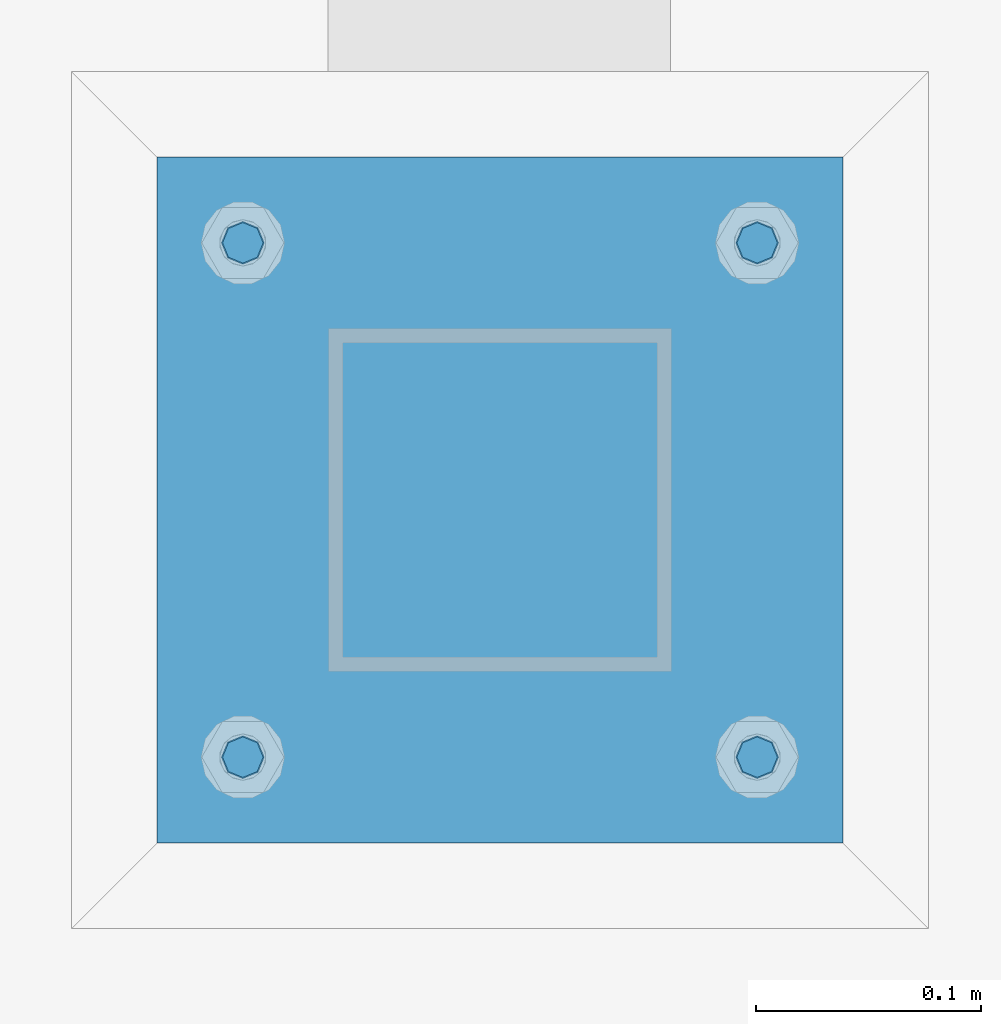
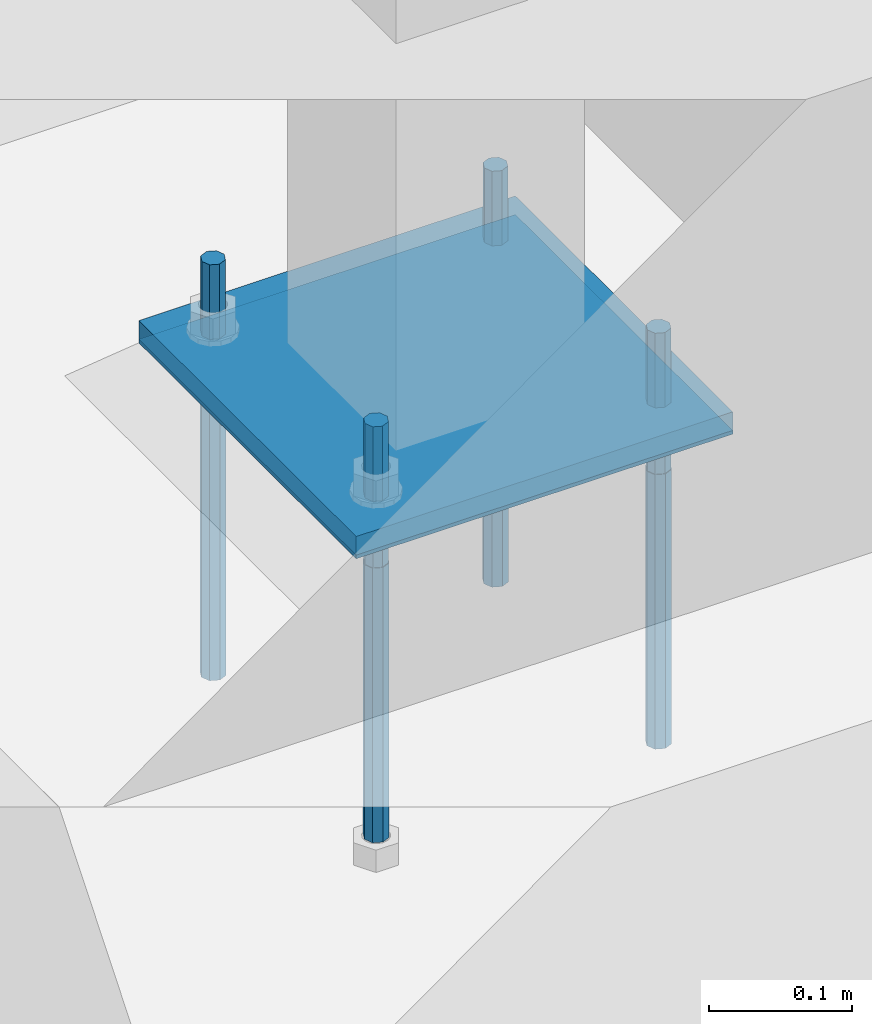
# One storey, part 852 of 1179: 6 beams, 2 elements without a shape of their own.
"""IFC2X3 building model written with IfcOpenShell, lengths in millimetres."""

from ifc_helpers import new_model, si_unit, frame, origin_with_axes, place, context, subcontext, project, spatial, faceted_brep, material, type_object, element, aggregate, save


model = new_model("IFC2X3")

# Units and contexts
model_context = context("Model", 3, precision=1e-05, world=origin_with_axes())
body_context = subcontext(model_context, "Body", "Model", "MODEL_VIEW")
ifc_project = project(units=[si_unit("LENGTHUNIT", "METRE", prefix="MILLI"), si_unit("AREAUNIT", "SQUARE_METRE"), si_unit("VOLUMEUNIT", "CUBIC_METRE"), si_unit("MASSUNIT", "GRAM", prefix="KILO"), si_unit("TIMEUNIT", "SECOND"), si_unit("PLANEANGLEUNIT", "RADIAN"), si_unit("SOLIDANGLEUNIT", "STERADIAN"), si_unit("THERMODYNAMICTEMPERATUREUNIT", "DEGREE_CELSIUS"), si_unit("LUMINOUSINTENSITYUNIT", "LUMEN")], contexts=[model_context])

# Site, building, storey
site_placement = place(None, origin_with_axes())
site = spatial("IfcSite", under=ifc_project, at=site_placement, CompositionType="ELEMENT")
building_placement = place(site_placement, origin_with_axes())
building = spatial("IfcBuilding", under=site, at=building_placement, Name="Undefined", CompositionType="ELEMENT")
storey_placement = place(building_placement, origin_with_axes())
storey = spatial("IfcBuildingStorey", under=building, at=storey_placement, Name="Undefined", CompositionType="ELEMENT", Elevation=0.0)

# Assembly, beam
assembly_1_placement = place(storey_placement, origin_with_axes())
assembly_1 = element("IfcElementAssembly", 1, at=assembly_1_placement, inside=storey, Name="COLUMN", AssemblyPlace="NOTDEFINED", PredefinedType="RIGID_FRAME")
ifc_material_1 = material(Name="STEEL/A572-GR.50")
beam_type_1 = type_object("IfcBeamType", PredefinedType="NOTDEFINED")
beam_1_placement = place(assembly_1_placement, frame((37084.0, 2082.80000305176, -765.175), z_axis=(-1.0, 0.0, 0.0), x_axis=(0.0, 1.0, 0.0)))
beam_1 = element("IfcBeam", 2, at=beam_1_placement, type_object=beam_type_1, material=ifc_material_1, context=body_context, shape_type="Brep", body=[
    faceted_brep([(0.0, 9.52500000000146, -152.4), (0.0, 9.52500000000146, 152.4), (304.799993896484, 9.52499999999998, 152.400000000001), (304.799993896484, 9.52499999999998, -152.400000000001), (0.0, -9.52500000000146, 152.4), (304.799993896484, -9.52499999999998, 152.400000000001), (0.0, -9.52500000000146, -152.4), (304.799993896484, -9.52499999999998, -152.400000000001)], [[[0, 1, 2, 3]], [[1, 4, 5, 2]], [[4, 6, 7, 5]], [[6, 0, 3, 7]], [[5, 7, 3, 2]], [[6, 4, 1, 0]]]),
])
aggregate(assembly_1, [beam_1])

# Assembly, beams
assembly_2_placement = place(storey_placement, origin_with_axes())
assembly_2 = element("IfcElementAssembly", 3, at=assembly_2_placement, inside=storey, Name="TEMPLATE", AssemblyPlace="NOTDEFINED", PredefinedType="RIGID_FRAME")
ifc_material_2 = material(Name="STEEL/F1554-GR.36")
beam_type_2 = type_object("IfcBeamType", PredefinedType="NOTDEFINED")
beam_2_placement = place(assembly_2_placement, frame((36969.7, 2120.9, -812.8), z_axis=(0.0, -1.0, 0.0), x_axis=(0.0, 0.0, -1.0)))
beam_2 = element("IfcBeam", 4, at=beam_2_placement, type_object=beam_type_2, material=ifc_material_2, Name="ANCHOR_BOLT", context=body_context, shape_type="Brep", body=[
    faceted_brep([(0.0, -6.73519209080177, -6.73519209080223), (2.95075507493764e-12, -3.62376795237651e-13, -9.52499961853027), (234.949, 0.0, -9.52500000000009), (234.949, -6.73519209080405, -6.73519209080177), (0.0, 6.73519209080177, -6.73519209080223), (234.949, 6.73519209080405, -6.73519209080177), (0.0, 9.52499999999964, 0.0), (234.949, 9.52500000000146, 0.0), (0.0, 6.73519209080177, 6.73519209080223), (234.949, 6.73519209080405, 6.73519209080177), (-9.87109982941227e-13, -3.62376795237651e-13, 9.52499961853027), (234.949, 0.0, 9.52500000000009), (0.0, -6.73519209080177, 6.73519209080223), (234.949, -6.73519209080405, 6.73519209080177), (0.0, -9.52499999999964, 0.0), (234.949, -9.52500000000146, 0.0), (0.0, 6.36396103067818, 6.36396103067909), (0.0, 0.0, 9.0), (0.0, -6.36396103067818, 6.36396103067909), (0.0, -9.0, 0.0), (0.0, -6.36396103067818, -6.36396103067909), (0.0, 0.0, -9.0), (0.0, 6.36396103067818, -6.36396103067909), (0.0, 9.0, 0.0), (-120.65, -6.36396103067818, 6.36396103067909), (-120.65, 0.0, 9.0), (-120.65, 6.36396103067818, 6.36396103067909), (-120.65, 9.0, 0.0), (-120.65, 6.36396103067818, -6.36396103067909), (-120.65, 0.0, -9.0), (-120.65, -6.36396103067818, -6.36396103067909), (-120.65, -9.0, 0.0)], [[[0, 1, 2, 3]], [[1, 4, 5, 2]], [[4, 6, 7, 5]], [[6, 8, 9, 7]], [[8, 10, 11, 9]], [[10, 12, 13, 11]], [[12, 14, 15, 13]], [[2, 5, 7, 9, 11, 13, 15, 3]], [[14, 0, 3, 15]], [[12, 10, 8, 6, 4, 1, 0, 14], [16, 17, 18, 19, 20, 21, 22, 23]], [[24, 25, 26, 27, 28, 29, 30, 31]], [[26, 25, 17, 16]], [[27, 26, 16, 23]], [[28, 27, 23, 22]], [[29, 28, 22, 21]], [[30, 29, 21, 20]], [[31, 30, 20, 19]], [[24, 31, 19, 18]], [[25, 24, 18, 17]]]),
])
beam_3_placement = place(assembly_2_placement, frame((37198.3, 2120.9, -812.8), z_axis=(0.0, 1.0, 0.0), x_axis=(0.0, 0.0, -1.0)))
beam_3 = element("IfcBeam", 5, at=beam_3_placement, type_object=beam_type_2, material=ifc_material_2, Name="ANCHOR_BOLT", context=body_context, shape_type="Brep", body=[
    faceted_brep([(0.0, -6.73519209080177, -6.73519209080223), (2.95075507493764e-12, -3.62376795237651e-13, -9.52499961853027), (234.949, 0.0, -9.52500000000009), (234.949, -6.73519209080405, -6.73519209080177), (0.0, 6.73519209080177, -6.73519209080223), (234.949, 6.73519209080405, -6.73519209080177), (0.0, 9.52499999999964, 0.0), (234.949, 9.52500000000146, 0.0), (0.0, 6.73519209080177, 6.73519209080223), (234.949, 6.73519209080405, 6.73519209080177), (-9.87109982941227e-13, -3.62376795237651e-13, 9.52499961853027), (234.949, 0.0, 9.52500000000009), (0.0, -6.73519209080177, 6.73519209080223), (234.949, -6.73519209080405, 6.73519209080177), (0.0, -9.52499999999964, 0.0), (234.949, -9.52500000000146, 0.0), (0.0, 6.36396103067818, 6.36396103067909), (0.0, 0.0, 9.0), (0.0, -6.36396103067818, 6.36396103067909), (0.0, -9.0, 0.0), (0.0, -6.36396103067818, -6.36396103067909), (0.0, 0.0, -9.0), (0.0, 6.36396103067818, -6.36396103067909), (0.0, 9.0, 0.0), (-120.65, -6.36396103067818, 6.36396103067909), (-120.65, 0.0, 9.0), (-120.65, 6.36396103067818, 6.36396103067909), (-120.65, 9.0, 0.0), (-120.65, 6.36396103067818, -6.36396103067909), (-120.65, 0.0, -9.0), (-120.65, -6.36396103067818, -6.36396103067909), (-120.65, -9.0, 0.0)], [[[0, 1, 2, 3]], [[1, 4, 5, 2]], [[4, 6, 7, 5]], [[6, 8, 9, 7]], [[8, 10, 11, 9]], [[10, 12, 13, 11]], [[12, 14, 15, 13]], [[2, 5, 7, 9, 11, 13, 15, 3]], [[14, 0, 3, 15]], [[12, 10, 8, 6, 4, 1, 0, 14], [16, 17, 18, 19, 20, 21, 22, 23]], [[24, 25, 26, 27, 28, 29, 30, 31]], [[26, 25, 17, 16]], [[27, 26, 16, 23]], [[28, 27, 23, 22]], [[29, 28, 22, 21]], [[30, 29, 21, 20]], [[31, 30, 20, 19]], [[24, 31, 19, 18]], [[25, 24, 18, 17]]]),
])
beam_4_placement = place(assembly_2_placement, frame((36969.7, 2349.5, -812.8), z_axis=(0.0, -1.0, 0.0), x_axis=(0.0, 0.0, -1.0)))
beam_4 = element("IfcBeam", 6, at=beam_4_placement, type_object=beam_type_2, material=ifc_material_2, Name="ANCHOR_BOLT", context=body_context, shape_type="Brep", body=[
    faceted_brep([(0.0, -6.73519209080177, -6.73519209080223), (2.95075507493764e-12, -3.62376795237651e-13, -9.52499961853027), (234.949, 0.0, -9.52500000000009), (234.949, -6.73519209080405, -6.73519209080177), (0.0, 6.73519209080177, -6.73519209080223), (234.949, 6.73519209080405, -6.73519209080177), (0.0, 9.52499999999964, 0.0), (234.949, 9.52500000000146, 0.0), (0.0, 6.73519209080177, 6.73519209080223), (234.949, 6.73519209080405, 6.73519209080177), (-9.87109982941227e-13, -3.62376795237651e-13, 9.52499961853027), (234.949, 0.0, 9.52500000000009), (0.0, -6.73519209080177, 6.73519209080223), (234.949, -6.73519209080405, 6.73519209080177), (0.0, -9.52499999999964, 0.0), (234.949, -9.52500000000146, 0.0), (0.0, 6.36396103067818, 6.36396103067909), (0.0, 0.0, 9.0), (0.0, -6.36396103067818, 6.36396103067909), (0.0, -9.0, 0.0), (0.0, -6.36396103067818, -6.36396103067909), (0.0, 0.0, -9.0), (0.0, 6.36396103067818, -6.36396103067909), (0.0, 9.0, 0.0), (-120.65, -6.36396103067818, 6.36396103067909), (-120.65, 0.0, 9.0), (-120.65, 6.36396103067818, 6.36396103067909), (-120.65, 9.0, 0.0), (-120.65, 6.36396103067818, -6.36396103067909), (-120.65, 0.0, -9.0), (-120.65, -6.36396103067818, -6.36396103067909), (-120.65, -9.0, 0.0)], [[[0, 1, 2, 3]], [[1, 4, 5, 2]], [[4, 6, 7, 5]], [[6, 8, 9, 7]], [[8, 10, 11, 9]], [[10, 12, 13, 11]], [[12, 14, 15, 13]], [[2, 5, 7, 9, 11, 13, 15, 3]], [[14, 0, 3, 15]], [[12, 10, 8, 6, 4, 1, 0, 14], [16, 17, 18, 19, 20, 21, 22, 23]], [[24, 25, 26, 27, 28, 29, 30, 31]], [[26, 25, 17, 16]], [[27, 26, 16, 23]], [[28, 27, 23, 22]], [[29, 28, 22, 21]], [[30, 29, 21, 20]], [[31, 30, 20, 19]], [[24, 31, 19, 18]], [[25, 24, 18, 17]]]),
])
beam_5_placement = place(assembly_2_placement, frame((37198.3, 2349.5, -812.8), z_axis=(0.0, 1.0, 0.0), x_axis=(0.0, 0.0, -1.0)))
beam_5 = element("IfcBeam", 7, at=beam_5_placement, type_object=beam_type_2, material=ifc_material_2, Name="ANCHOR_BOLT", context=body_context, shape_type="Brep", body=[
    faceted_brep([(0.0, -6.73519209080177, -6.73519209080223), (2.95075507493764e-12, -3.62376795237651e-13, -9.52499961853027), (234.949, 0.0, -9.52500000000009), (234.949, -6.73519209080405, -6.73519209080177), (0.0, 6.73519209080177, -6.73519209080223), (234.949, 6.73519209080405, -6.73519209080177), (0.0, 9.52499999999964, 0.0), (234.949, 9.52500000000146, 0.0), (0.0, 6.73519209080177, 6.73519209080223), (234.949, 6.73519209080405, 6.73519209080177), (-9.87109982941227e-13, -3.62376795237651e-13, 9.52499961853027), (234.949, 0.0, 9.52500000000009), (0.0, -6.73519209080177, 6.73519209080223), (234.949, -6.73519209080405, 6.73519209080177), (0.0, -9.52499999999964, 0.0), (234.949, -9.52500000000146, 0.0), (0.0, 6.36396103067818, 6.36396103067909), (0.0, 0.0, 9.0), (0.0, -6.36396103067818, 6.36396103067909), (0.0, -9.0, 0.0), (0.0, -6.36396103067818, -6.36396103067909), (0.0, 0.0, -9.0), (0.0, 6.36396103067818, -6.36396103067909), (0.0, 9.0, 0.0), (-120.65, -6.36396103067818, 6.36396103067909), (-120.65, 0.0, 9.0), (-120.65, 6.36396103067818, 6.36396103067909), (-120.65, 9.0, 0.0), (-120.65, 6.36396103067818, -6.36396103067909), (-120.65, 0.0, -9.0), (-120.65, -6.36396103067818, -6.36396103067909), (-120.65, -9.0, 0.0)], [[[0, 1, 2, 3]], [[1, 4, 5, 2]], [[4, 6, 7, 5]], [[6, 8, 9, 7]], [[8, 10, 11, 9]], [[10, 12, 13, 11]], [[12, 14, 15, 13]], [[2, 5, 7, 9, 11, 13, 15, 3]], [[14, 0, 3, 15]], [[12, 10, 8, 6, 4, 1, 0, 14], [16, 17, 18, 19, 20, 21, 22, 23]], [[24, 25, 26, 27, 28, 29, 30, 31]], [[26, 25, 17, 16]], [[27, 26, 16, 23]], [[28, 27, 23, 22]], [[29, 28, 22, 21]], [[30, 29, 21, 20]], [[31, 30, 20, 19]], [[24, 31, 19, 18]], [[25, 24, 18, 17]]]),
])
ifc_material_3 = material(Name="STEEL/A36")
beam_type_3 = type_object("IfcBeamType", PredefinedType="NOTDEFINED")
beam_6_placement = place(assembly_2_placement, frame((37084.0, 2082.80000305176, -773.1125), z_axis=(-1.0, 0.0, 0.0), x_axis=(0.0, 1.0, 0.0)))
beam_6 = element("IfcBeam", 8, at=beam_6_placement, type_object=beam_type_3, material=ifc_material_3, Name="TEMPLATE", context=body_context, shape_type="Brep", body=[
    faceted_brep([(0.0, 1.58750000000146, -152.4), (0.0, 1.58750000000146, 152.4), (304.799999999996, 1.58749999999998, 152.400000000001), (304.799999999996, 1.58749999999998, -152.400000000001), (0.0, -1.58750000000146, 152.4), (304.799999999996, -1.58749999999998, 152.400000000001), (0.0, -1.58750000000146, -152.4), (304.799999999996, -1.58749999999998, -152.400000000001)], [[[0, 1, 2, 3]], [[1, 4, 5, 2]], [[4, 6, 7, 5]], [[6, 0, 3, 7]], [[5, 7, 3, 2]], [[6, 4, 1, 0]]]),
])
aggregate(assembly_2, [beam_2, beam_3, beam_4, beam_5, beam_6])

save(model, "model.ifc")
